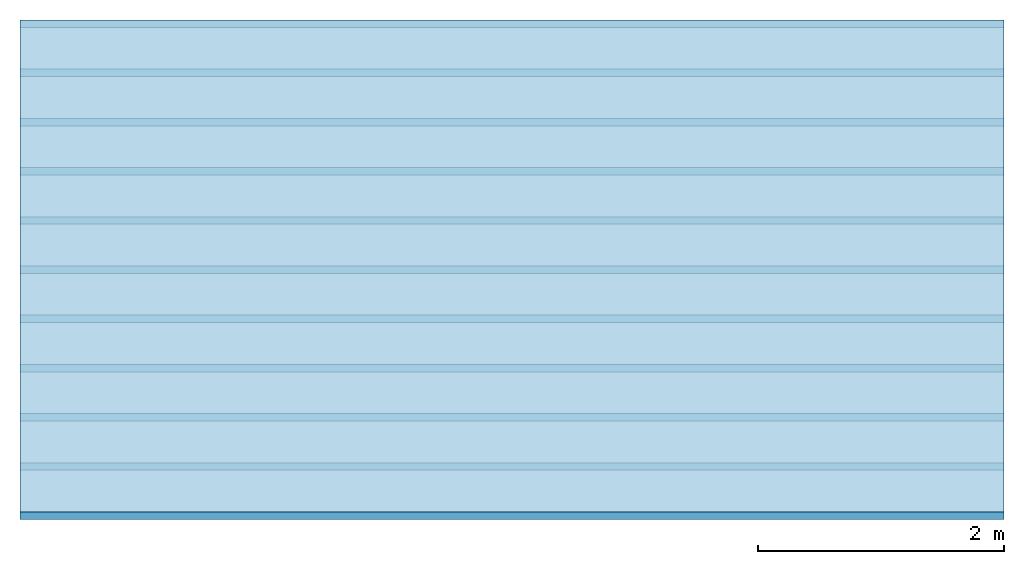
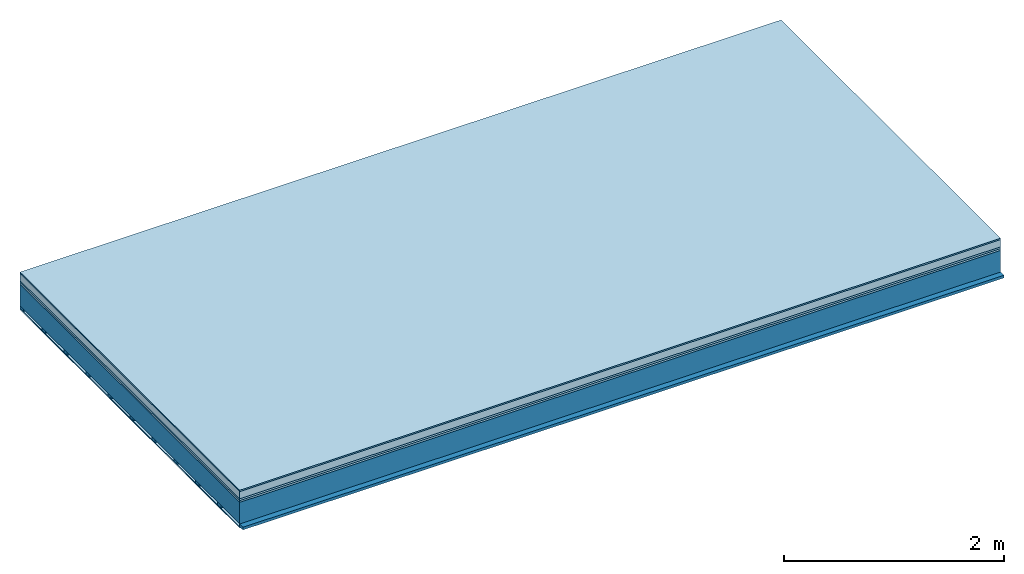
# One storey: 6 plates, 2 members, 1 element without a shape of its own.
"""IFC4 building model written with IfcOpenShell, lengths in metres."""

import ifcopenshell
import ifcopenshell.guid

model = None  # the IFC model being written
_history = None  # IfcOwnerHistory: only IFC2X3 demands one
_inside = {}  # id of a spatial element -> (the spatial element, [elements in it])
_under = {}  # id of a project, library or spatial element -> (it, [spatial elements below it])
_declared = {}  # id of a project -> (the project, [libraries it declares])
_typed = {}  # id of a type object -> (the type object, [elements of that type])
_made_of = {}  # id of a material, layer set ... -> (it, [elements and type objects made of it])


def new_model(schema):
    """Start an empty IFC model of exactly this schema.

    Asked for "IFC4X3", IfcOpenShell would pick the latest addendum, in which some entities
    have other attributes; the version numbers below select the first issue.
    IFC2X3 requires an IfcOwnerHistory on every rooted entity: one is made here for all.
    """
    global model, _history
    if schema == "IFC4X3":
        model = ifcopenshell.file(schema_version=(4, 3, 0, 0))
    else:
        model = ifcopenshell.file(schema=schema)
    _inside.clear()
    _under.clear()
    _declared.clear()
    _typed.clear()
    _made_of.clear()
    _history = None
    if model.schema == "IFC2X3":
        org = make("IfcOrganization", Name="unknown")
        user = make(
            "IfcPersonAndOrganization",
            ThePerson=make("IfcPerson", FamilyName="unknown"),
            TheOrganization=org,
        )
        app = make(
            "IfcApplication",
            ApplicationDeveloper=org,
            Version="unknown",
            ApplicationFullName="unknown",
            ApplicationIdentifier="unknown",
        )
        _history = make(
            "IfcOwnerHistory",
            OwningUser=user,
            OwningApplication=app,
            ChangeAction="ADDED",
            CreationDate=0,
        )
    return model


def make(cls, **values):
    """One entity of the class cls with the attributes given. An attribute that is None is left unset."""
    return model.create_entity(
        cls, **{name: value for name, value in values.items() if value is not None}
    )


def rooted(cls, **values):
    """An entity with a GlobalId (a new one), such as an element, a storey or a relation."""
    return make(cls, GlobalId=ifcopenshell.guid.new(), OwnerHistory=_history, **values)


def si_unit(unit_type, name, prefix=None):
    """IfcSIUnit, for example si_unit("LENGTHUNIT", "METRE", prefix="MILLI")."""
    return make("IfcSIUnit", UnitType=unit_type, Prefix=prefix, Name=name)


def derived_unit(unit_type, elements):
    """IfcDerivedUnit: a product of units, each with its exponent."""
    return make(
        "IfcDerivedUnit",
        Elements=[
            make("IfcDerivedUnitElement", Unit=unit, Exponent=power)
            for unit, power in elements
        ],
        UnitType=unit_type,
    )


def assignment(units):
    """IfcUnitAssignment: the units of a project."""
    return None if units is None else make("IfcUnitAssignment", Units=units)


def point(xyz):
    """IfcCartesianPoint."""
    return None if xyz is None else make("IfcCartesianPoint", Coordinates=xyz)


def direction(xyz):
    """IfcDirection."""
    return None if xyz is None else make("IfcDirection", DirectionRatios=xyz)


def frame(location, z_axis=None, x_axis=None):
    """IfcAxis2Placement3D, a coordinate frame: its origin and axes. An axis left out is left unset."""
    return make(
        "IfcAxis2Placement3D",
        Location=point(location),
        Axis=direction(z_axis),
        RefDirection=direction(x_axis),
    )


def frame_2d(location, x_axis=None):
    """IfcAxis2Placement2D, a coordinate frame in the plane: its origin and x axis."""
    return make(
        "IfcAxis2Placement2D", Location=point(location), RefDirection=direction(x_axis)
    )


def origin():
    """The frame at (0, 0, 0) with its axes left unset."""
    return frame((0.0, 0.0, 0.0))


def origin_with_axes():
    """The frame at (0, 0, 0) with the z axis (0, 0, 1) and the x axis (1, 0, 0) written out."""
    return frame((0.0, 0.0, 0.0), z_axis=(0.0, 0.0, 1.0), x_axis=(1.0, 0.0, 0.0))


def place(relative_to, where):
    """IfcLocalPlacement: puts the frame where relative to a parent placement (None: the world)."""
    return make(
        "IfcLocalPlacement", PlacementRelTo=relative_to, RelativePlacement=where
    )


def context(
    kind, dimensions, precision=None, world=None, true_north=None, identifier=None
):
    """IfcGeometricRepresentationContext, for example the 3D "Model" context."""
    return make(
        "IfcGeometricRepresentationContext",
        ContextIdentifier=identifier,
        ContextType=kind,
        CoordinateSpaceDimension=dimensions,
        Precision=precision,
        WorldCoordinateSystem=world,
        TrueNorth=true_north,
    )


def project(units=None, contexts=None):
    """IfcProject with its units and contexts."""
    return rooted(
        "IfcProject",
        Name="project",
        RepresentationContexts=contexts,
        UnitsInContext=assignment(units),
    )


def spatial(cls, under=None, at=None, **own):
    """A site, building, storey or space (cls), placed at a placement, below another one or the project."""
    s = rooted(cls, ObjectPlacement=at, **own)
    if under is not None:
        _under.setdefault(under.id(), (under, []))[1].append(s)
    return s


def profile(cls, at=None, kind="AREA", **sizes):
    """A parametric profile (cls). Its sizes go by their IFC names, for example OverallWidth=200.0."""
    return make(cls, ProfileType=kind, Position=at, **sizes)


def rectangle(**sizes):
    """IfcRectangleProfileDef."""
    return profile("IfcRectangleProfileDef", **sizes)


def extrude(swept, where, along, depth):
    """IfcExtrudedAreaSolid: the profile swept, set in the frame where, extruded along a direction by depth."""
    return make(
        "IfcExtrudedAreaSolid",
        SweptArea=swept,
        Position=where,
        ExtrudedDirection=direction(along),
        Depth=depth,
    )


def shape(context_of_items, identifier, shape_type, items):
    """IfcShapeRepresentation: the items that make up one representation, for example the "Body"."""
    return make(
        "IfcShapeRepresentation",
        ContextOfItems=context_of_items,
        RepresentationIdentifier=identifier,
        RepresentationType=shape_type,
        Items=items,
    )


def material(Name=None, Category=None):
    """IfcMaterial."""
    return make("IfcMaterial", Name=Name, Category=Category)


def layer(
    of_material, thickness, ventilated=None, Name=None, Category=None, Priority=None
):
    """IfcMaterialLayer: one layer of a wall or slab, of a material (None: an air gap)."""
    return make(
        "IfcMaterialLayer",
        Material=of_material,
        LayerThickness=thickness,
        IsVentilated=ventilated,
        Name=Name,
        Category=Category,
        Priority=Priority,
    )


def layer_set(layers, Name=None):
    """IfcMaterialLayerSet."""
    return make("IfcMaterialLayerSet", MaterialLayers=layers, LayerSetName=Name)


def made_of(thing, what):
    """Note that an element or type object is made of a material, layer set ...; save() writes the relation."""
    if what is not None:
        _made_of.setdefault(what.id(), (what, []))[1].append(thing)
    return thing


def type_object(cls, material=None, **own):
    """A type object (cls), such as IfcWallType, which elements share."""
    return made_of(rooted(cls, **own), material)


def element(
    cls,
    number,
    at=None,
    inside=None,
    cuts=None,
    type_object=None,
    material=None,
    context=None,
    identifier="Body",
    shape_type=None,
    held_by="IfcProductDefinitionShape",
    body=None,
    shapes=None,
    **own,
):
    """One element of the class cls, such as IfcWall. Its Tag is "e" and its number.

    at: its placement. inside: the storey or other place that contains it. cuts: it is an
    opening in that element (IfcRelVoidsElement). A single representation is given by context,
    identifier, shape_type and body (its items); several are given by shapes. held_by: the class
    of the entity that holds the representations. save() writes the other relations.
    """
    e = rooted(cls, Tag="e%d" % number, ObjectPlacement=at, **own)
    if body is not None:
        shapes = [shape(context, identifier, shape_type, body)]
    if shapes is not None:
        e.Representation = make(held_by, Representations=shapes)
    if inside is not None:
        _inside.setdefault(inside.id(), (inside, []))[1].append(e)
    if cuts is not None:
        rooted(
            "IfcRelVoidsElement", RelatingBuildingElement=cuts, RelatedOpeningElement=e
        )
    if type_object is not None:
        _typed.setdefault(type_object.id(), (type_object, []))[1].append(e)
    return made_of(e, material)


def aggregate(whole, parts):
    """IfcRelAggregates: a whole, such as a stair, and the parts it consists of."""
    return rooted("IfcRelAggregates", RelatingObject=whole, RelatedObjects=parts)


def save(model, path):
    """Write the relations noted so far, then the file.

    IfcRelAggregates (storeys below a building ...), IfcRelContainedInSpatialStructure (elements
    in a storey), IfcRelDefinesByType, IfcRelAssociatesMaterial and IfcRelDeclares: one each for
    every whole, place, type object, material and project.
    """
    for whole, parts in _under.values():
        aggregate(whole, parts)
    for where, things in _inside.values():
        rooted(
            "IfcRelContainedInSpatialStructure",
            RelatedElements=things,
            RelatingStructure=where,
        )
    for kind, things in _typed.values():
        rooted("IfcRelDefinesByType", RelatedObjects=things, RelatingType=kind)
    for what, things in _made_of.values():
        rooted("IfcRelAssociatesMaterial", RelatedObjects=things, RelatingMaterial=what)
    for by, libraries in _declared.values():
        rooted("IfcRelDeclares", RelatingContext=by, RelatedDefinitions=libraries)
    model.write(path)


model = new_model("IFC4")

# Units and contexts
plan_context = context("Plan", 3, precision=1e-05, world=origin(), true_north=direction((0.0, 1.0)))
model_context = context("Model", 3, precision=1e-05, world=origin(), true_north=direction((0.0, 1.0)))
ifc_project = project(units=[si_unit("LENGTHUNIT", "METRE"), derived_unit("SOUNDPRESSUREUNIT", [(si_unit("PRESSUREUNIT", "PASCAL", prefix="MICRO"), 0)]), si_unit("ENERGYUNIT", "JOULE", prefix="MEGA"), si_unit("MASSUNIT", "GRAM", prefix="KILO"), derived_unit("THERMALTRANSMITTANCEUNIT", [(si_unit("POWERUNIT", "WATT"), 1), (si_unit("AREAUNIT", "SQUARE_METRE"), -1), (si_unit("THERMODYNAMICTEMPERATUREUNIT", "KELVIN"), -1)]), derived_unit("AREADENSITYUNIT", [(si_unit("MASSUNIT", "GRAM", prefix="KILO"), 1), (si_unit("AREAUNIT", "SQUARE_METRE"), -1)]), derived_unit("USERDEFINED", [(si_unit("ENERGYUNIT", "JOULE", prefix="MEGA"), 1), (si_unit("AREAUNIT", "SQUARE_METRE"), -1)])], contexts=[plan_context, model_context])

# Site, building, storey
site = spatial("IfcSite", under=ifc_project)
building_placement = place(None, origin())
building = spatial("IfcBuilding", under=site, at=building_placement)
storey_placement = place(building_placement, origin())
storey = spatial("IfcBuildingStorey", under=building, at=storey_placement)

# Slab, members, plates
ifc_material_1 = material(Category="11.013")
ifc_layer_1 = layer(ifc_material_1, 0.015, Name="Flooring")
ifc_material_2 = material(Name="Cement screed", Category="04.006")
ifc_layer_2 = layer(ifc_material_2, 0.08, Name="On-material")
ifc_material_3 = material(Name="Wood fiber generic product", Category="10.009")
ifc_layer_3 = layer(ifc_material_3, 0.02, Name="Impact sound insulation")
ifc_material_4 = material(Category="10.004")
ifc_layer_4 = layer(ifc_material_4, 0.02, Name="Additional insulation")
ifc_material_5 = material(Name="no composite action")
ifc_layer_5 = layer(ifc_material_5, 0.0, Name="Bond")
ifc_layer_6 = layer(None, 0.24, Name="Supporting structure")
ifc_material_6 = material(Name="of the art")
ifc_layer_7 = layer(ifc_material_6, 0.0, Name="Bond")
ifc_layer_8 = layer(None, 0.03, Name="Battens / profiles")
ifc_material_7 = material(Name="Plasterboard type A", Category="03.008")
ifc_layer_9 = layer(ifc_material_7, 0.0125, Name="Ceiling covering 1st layer")
ifc_material_8 = material(Category="04.001")
ifc_layer_10 = layer(ifc_material_8, 0.003, Name="Surface / treatment")
ifc_layer_set = layer_set([ifc_layer_1, ifc_layer_2, ifc_layer_3, ifc_layer_4, ifc_layer_5, ifc_layer_6, ifc_layer_7, ifc_layer_8, ifc_layer_9, ifc_layer_10])
slab_type = type_object("IfcSlabType", Name="A2147", PredefinedType="NOTDEFINED", material=ifc_layer_set)
slab_placement = place(None, frame((0.0, 0.0, 0.0), z_axis=(0.0, 0.0, -1.0), x_axis=(1.0, 0.0, 0.0)))
slab = element("IfcSlab", 1, at=slab_placement, inside=storey, type_object=slab_type, material=ifc_layer_set, Name="Slab #1")
ifc_material_9 = material(Name="Solid timber panel")
member_1_placement = place(slab_placement, origin())
member_1 = element("IfcMember", 2, at=member_1_placement, material=ifc_material_9, Name="Supporting structure", context=plan_context, shape_type="SweptSolid", body=[
    extrude(rectangle(XDim=1.0, YDim=0.24, at=frame_2d((0.5, 0.12), x_axis=(1.0, 0.0))), frame((0.0, 4.0, 0.135), z_axis=(0.0, -1.0, 0.0), x_axis=(1.0, 0.0, 0.0)), (0.0, 0.0, 1.0), 4.0),
    extrude(rectangle(XDim=1.0, YDim=0.24, at=frame_2d((0.5, 0.12), x_axis=(1.0, 0.0))), frame((1.0, 4.0, 0.135), z_axis=(0.0, -1.0, 0.0), x_axis=(1.0, 0.0, 0.0)), (0.0, 0.0, 1.0), 4.0),
    extrude(rectangle(XDim=1.0, YDim=0.24, at=frame_2d((0.5, 0.12), x_axis=(1.0, 0.0))), frame((2.0, 4.0, 0.135), z_axis=(0.0, -1.0, 0.0), x_axis=(1.0, 0.0, 0.0)), (0.0, 0.0, 1.0), 4.0),
    extrude(rectangle(XDim=1.0, YDim=0.24, at=frame_2d((0.5, 0.12), x_axis=(1.0, 0.0))), frame((3.0, 4.0, 0.135), z_axis=(0.0, -1.0, 0.0), x_axis=(1.0, 0.0, 0.0)), (0.0, 0.0, 1.0), 4.0),
    extrude(rectangle(XDim=1.0, YDim=0.24, at=frame_2d((0.5, 0.12), x_axis=(1.0, 0.0))), frame((4.0, 4.0, 0.135), z_axis=(0.0, -1.0, 0.0), x_axis=(1.0, 0.0, 0.0)), (0.0, 0.0, 1.0), 4.0),
    extrude(rectangle(XDim=1.0, YDim=0.24, at=frame_2d((0.5, 0.12), x_axis=(1.0, 0.0))), frame((5.0, 4.0, 0.135), z_axis=(0.0, -1.0, 0.0), x_axis=(1.0, 0.0, 0.0)), (0.0, 0.0, 1.0), 4.0),
    extrude(rectangle(XDim=1.0, YDim=0.24, at=frame_2d((0.5, 0.12), x_axis=(1.0, 0.0))), frame((6.0, 4.0, 0.135), z_axis=(0.0, -1.0, 0.0), x_axis=(1.0, 0.0, 0.0)), (0.0, 0.0, 1.0), 4.0),
    extrude(rectangle(XDim=1.0, YDim=0.24, at=frame_2d((0.5, 0.12), x_axis=(1.0, 0.0))), frame((7.0, 4.0, 0.135), z_axis=(0.0, -1.0, 0.0), x_axis=(1.0, 0.0, 0.0)), (0.0, 0.0, 1.0), 4.0),
])
ifc_material_10 = material()
member_2_placement = place(slab_placement, origin())
member_2 = element("IfcMember", 3, at=member_2_placement, material=ifc_material_10, Name="Battens / profiles", context=plan_context, shape_type="SweptSolid", body=[
    extrude(rectangle(XDim=0.06, YDim=0.03, at=frame_2d((0.03, 0.015), x_axis=(1.0, 0.0))), frame((0.0, 0.0, 0.375), z_axis=(1.0, 0.0, 0.0), x_axis=(0.0, 1.0, 0.0)), (0.0, 0.0, 1.0), 8.0),
    extrude(rectangle(XDim=0.06, YDim=0.03, at=frame_2d((0.03, 0.015), x_axis=(1.0, 0.0))), frame((0.0, 0.4, 0.375), z_axis=(1.0, 0.0, 0.0), x_axis=(0.0, 1.0, 0.0)), (0.0, 0.0, 1.0), 8.0),
    extrude(rectangle(XDim=0.06, YDim=0.03, at=frame_2d((0.03, 0.015), x_axis=(1.0, 0.0))), frame((0.0, 0.8, 0.375), z_axis=(1.0, 0.0, 0.0), x_axis=(0.0, 1.0, 0.0)), (0.0, 0.0, 1.0), 8.0),
    extrude(rectangle(XDim=0.06, YDim=0.03, at=frame_2d((0.03, 0.015), x_axis=(1.0, 0.0))), frame((0.0, 1.2, 0.375), z_axis=(1.0, 0.0, 0.0), x_axis=(0.0, 1.0, 0.0)), (0.0, 0.0, 1.0), 8.0),
    extrude(rectangle(XDim=0.06, YDim=0.03, at=frame_2d((0.03, 0.015), x_axis=(1.0, 0.0))), frame((0.0, 1.6, 0.375), z_axis=(1.0, 0.0, 0.0), x_axis=(0.0, 1.0, 0.0)), (0.0, 0.0, 1.0), 8.0),
    extrude(rectangle(XDim=0.06, YDim=0.03, at=frame_2d((0.03, 0.015), x_axis=(1.0, 0.0))), frame((0.0, 2.0, 0.375), z_axis=(1.0, 0.0, 0.0), x_axis=(0.0, 1.0, 0.0)), (0.0, 0.0, 1.0), 8.0),
    extrude(rectangle(XDim=0.06, YDim=0.03, at=frame_2d((0.03, 0.015), x_axis=(1.0, 0.0))), frame((0.0, 2.4, 0.375), z_axis=(1.0, 0.0, 0.0), x_axis=(0.0, 1.0, 0.0)), (0.0, 0.0, 1.0), 8.0),
    extrude(rectangle(XDim=0.06, YDim=0.03, at=frame_2d((0.03, 0.015), x_axis=(1.0, 0.0))), frame((0.0, 2.8, 0.375), z_axis=(1.0, 0.0, 0.0), x_axis=(0.0, 1.0, 0.0)), (0.0, 0.0, 1.0), 8.0),
    extrude(rectangle(XDim=0.06, YDim=0.03, at=frame_2d((0.03, 0.015), x_axis=(1.0, 0.0))), frame((0.0, 3.2, 0.375), z_axis=(1.0, 0.0, 0.0), x_axis=(0.0, 1.0, 0.0)), (0.0, 0.0, 1.0), 8.0),
    extrude(rectangle(XDim=0.06, YDim=0.03, at=frame_2d((0.03, 0.015), x_axis=(1.0, 0.0))), frame((0.0, 3.6, 0.375), z_axis=(1.0, 0.0, 0.0), x_axis=(0.0, 1.0, 0.0)), (0.0, 0.0, 1.0), 8.0),
    extrude(rectangle(XDim=0.06, YDim=0.03, at=frame_2d((0.03, 0.015), x_axis=(1.0, 0.0))), frame((0.0, 4.0, 0.375), z_axis=(1.0, 0.0, 0.0), x_axis=(0.0, 1.0, 0.0)), (0.0, 0.0, 1.0), 8.0),
])
plate_1_placement = place(slab_placement, origin())
plate_1 = element("IfcPlate", 4, at=plate_1_placement, material=ifc_material_1, Name="Flooring", context=plan_context, shape_type="SweptSolid", body=[
    extrude(rectangle(XDim=8.0, YDim=4.0, at=frame_2d((4.0, 2.0), x_axis=(1.0, 0.0))), origin_with_axes(), (0.0, 0.0, 1.0), 0.015),
])
plate_2_placement = place(slab_placement, origin())
plate_2 = element("IfcPlate", 5, at=plate_2_placement, material=ifc_material_2, Name="On-material", context=plan_context, shape_type="SweptSolid", body=[
    extrude(rectangle(XDim=8.0, YDim=4.0, at=frame_2d((4.0, 2.0), x_axis=(1.0, 0.0))), frame((0.0, 0.0, 0.015), z_axis=(0.0, 0.0, 1.0), x_axis=(1.0, 0.0, 0.0)), (0.0, 0.0, 1.0), 0.08),
])
plate_3_placement = place(slab_placement, origin())
plate_3 = element("IfcPlate", 6, at=plate_3_placement, material=ifc_material_3, Name="Impact sound insulation", context=plan_context, shape_type="SweptSolid", body=[
    extrude(rectangle(XDim=8.0, YDim=4.0, at=frame_2d((4.0, 2.0), x_axis=(1.0, 0.0))), frame((0.0, 0.0, 0.095), z_axis=(0.0, 0.0, 1.0), x_axis=(1.0, 0.0, 0.0)), (0.0, 0.0, 1.0), 0.02),
])
plate_4_placement = place(slab_placement, origin())
plate_4 = element("IfcPlate", 7, at=plate_4_placement, material=ifc_material_4, Name="Additional insulation", context=plan_context, shape_type="SweptSolid", body=[
    extrude(rectangle(XDim=8.0, YDim=4.0, at=frame_2d((4.0, 2.0), x_axis=(1.0, 0.0))), frame((0.0, 0.0, 0.115), z_axis=(0.0, 0.0, 1.0), x_axis=(1.0, 0.0, 0.0)), (0.0, 0.0, 1.0), 0.02),
])
plate_5_placement = place(slab_placement, origin())
plate_5 = element("IfcPlate", 8, at=plate_5_placement, material=ifc_material_7, Name="Ceiling covering 1st layer", context=plan_context, shape_type="SweptSolid", body=[
    extrude(rectangle(XDim=8.0, YDim=4.0, at=frame_2d((4.0, 2.0), x_axis=(1.0, 0.0))), frame((0.0, 0.0, 0.405), z_axis=(0.0, 0.0, 1.0), x_axis=(1.0, 0.0, 0.0)), (0.0, 0.0, 1.0), 0.0125),
])
plate_6_placement = place(slab_placement, origin())
plate_6 = element("IfcPlate", 9, at=plate_6_placement, material=ifc_material_8, Name="Surface / treatment", context=plan_context, shape_type="SweptSolid", body=[
    extrude(rectangle(XDim=8.0, YDim=4.0, at=frame_2d((4.0, 2.0), x_axis=(1.0, 0.0))), frame((0.0, 0.0, 0.4175), z_axis=(0.0, 0.0, 1.0), x_axis=(1.0, 0.0, 0.0)), (0.0, 0.0, 1.0), 0.003),
])
aggregate(slab, [plate_1, plate_2, plate_3, plate_4, member_1, member_2, plate_5, plate_6])

save(model, "model.ifc")
